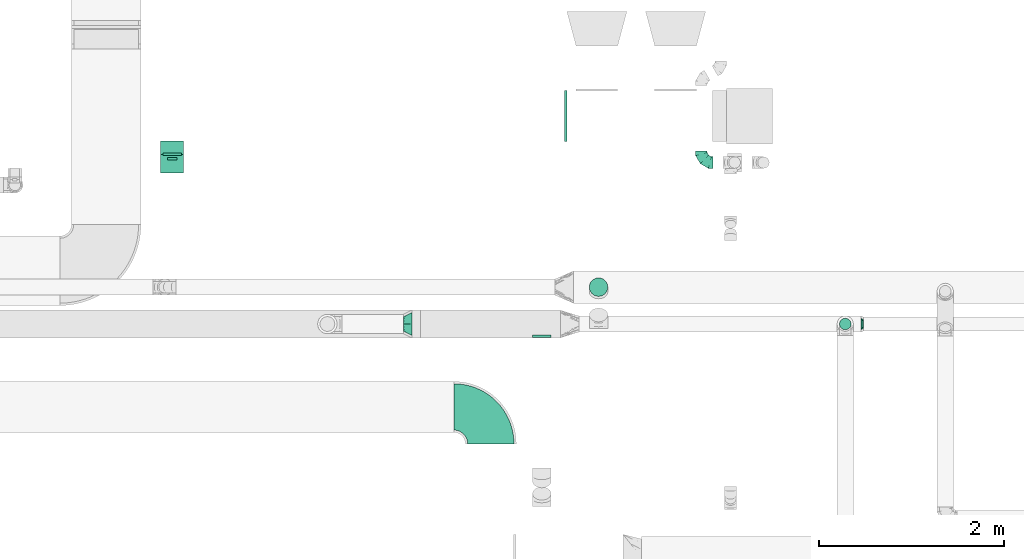
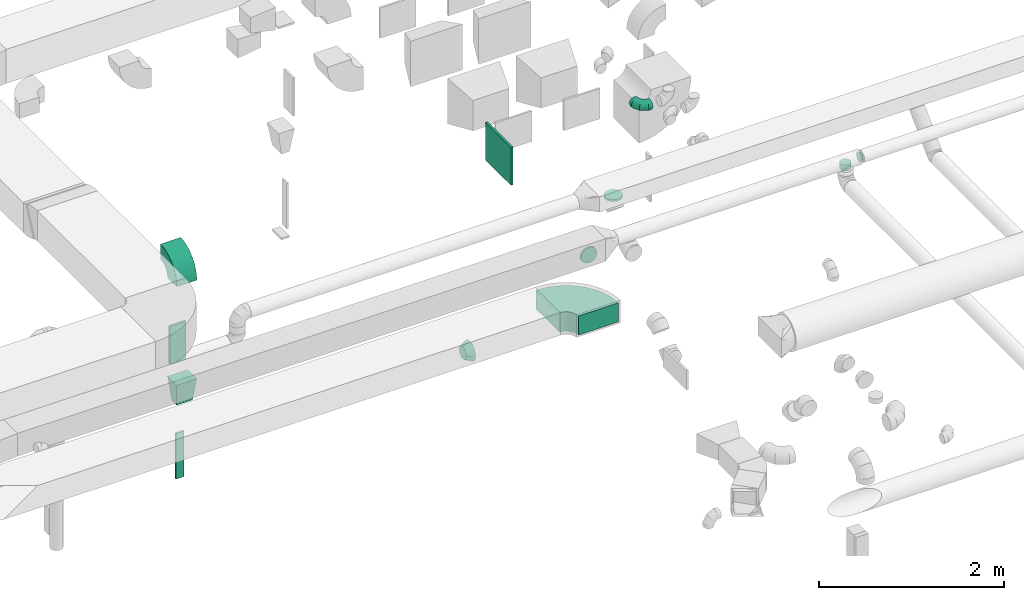
# One storey, part 56 of 97: 12 flow fittings.
"""IFC2X3 building model written with IfcOpenShell, lengths in millimetres."""

from ifc_helpers import new_model, entity, si_unit, converted_unit, derived_unit, direction, frame, frame_2d, origin, origin_2d_with_axis, place, context, subcontext, project, spatial, polyline, circle_curve, parameter, trimmed, segment, composite_curve, rectangle, outline, extrude, faceted_brep, source, transform, mapped, material, type_object, type_shapes, element, save


model = new_model("IFC2X3")

# Units and contexts
model_context = context("Model", 3, precision=0.01, world=origin(), true_north=direction((6.12303176911189e-17, 1.0)))
body_context = subcontext(model_context, "Body", "Model", "MODEL_VIEW")
ifc_project = project(units=[si_unit("LENGTHUNIT", "METRE", prefix="MILLI"), si_unit("AREAUNIT", "SQUARE_METRE"), si_unit("VOLUMEUNIT", "CUBIC_METRE"), converted_unit("PLANEANGLEUNIT", "DEGREE", entity("IfcRatioMeasure", 0.0174532925199433), si_unit("PLANEANGLEUNIT", "RADIAN"), dimensions=[0, 0, 0, 0, 0, 0, 0]), si_unit("MASSUNIT", "GRAM", prefix="KILO"), derived_unit("MASSDENSITYUNIT", [(si_unit("MASSUNIT", "GRAM", prefix="KILO"), 1), (si_unit("LENGTHUNIT", "METRE"), -3)]), derived_unit("MOMENTOFINERTIAUNIT", [(si_unit("LENGTHUNIT", "METRE"), 4)]), si_unit("TIMEUNIT", "SECOND"), si_unit("FREQUENCYUNIT", "HERTZ"), si_unit("THERMODYNAMICTEMPERATUREUNIT", "DEGREE_CELSIUS"), derived_unit("THERMALTRANSMITTANCEUNIT", [(si_unit("MASSUNIT", "GRAM", prefix="KILO"), 1), (si_unit("THERMODYNAMICTEMPERATUREUNIT", "KELVIN"), -1), (si_unit("TIMEUNIT", "SECOND"), -3)]), derived_unit("VOLUMETRICFLOWRATEUNIT", [(si_unit("LENGTHUNIT", "METRE"), 3), (si_unit("TIMEUNIT", "SECOND"), -1)]), derived_unit("MASSFLOWRATEUNIT", [(si_unit("MASSUNIT", "GRAM", prefix="KILO"), 1), (si_unit("TIMEUNIT", "SECOND"), -1)]), derived_unit("ROTATIONALFREQUENCYUNIT", [(si_unit("TIMEUNIT", "SECOND"), -1)]), si_unit("ELECTRICCURRENTUNIT", "AMPERE"), si_unit("ELECTRICVOLTAGEUNIT", "VOLT"), si_unit("POWERUNIT", "WATT"), si_unit("FORCEUNIT", "NEWTON", prefix="KILO"), si_unit("ILLUMINANCEUNIT", "LUX"), si_unit("LUMINOUSFLUXUNIT", "LUMEN"), si_unit("LUMINOUSINTENSITYUNIT", "CANDELA"), derived_unit("USERDEFINED", [(si_unit("MASSUNIT", "GRAM", prefix="KILO"), -1), (si_unit("LENGTHUNIT", "METRE"), -2), (si_unit("TIMEUNIT", "SECOND"), 3), (si_unit("LUMINOUSFLUXUNIT", "LUMEN"), 1)]), derived_unit("LINEARVELOCITYUNIT", [(si_unit("LENGTHUNIT", "METRE"), 1), (si_unit("TIMEUNIT", "SECOND"), -1)]), si_unit("PRESSUREUNIT", "PASCAL"), derived_unit("USERDEFINED", [(si_unit("LENGTHUNIT", "METRE"), -2), (si_unit("MASSUNIT", "GRAM", prefix="KILO"), 1), (si_unit("TIMEUNIT", "SECOND"), -2)]), derived_unit("LINEARFORCEUNIT", [(si_unit("MASSUNIT", "GRAM", prefix="KILO"), 1), (si_unit("LENGTHUNIT", "METRE"), 1), (si_unit("TIMEUNIT", "SECOND"), -2), (si_unit("LENGTHUNIT", "METRE"), -1)]), derived_unit("PLANARFORCEUNIT", [(si_unit("MASSUNIT", "GRAM", prefix="KILO"), 1), (si_unit("LENGTHUNIT", "METRE"), 1), (si_unit("TIMEUNIT", "SECOND"), -2), (si_unit("LENGTHUNIT", "METRE"), -2)])], contexts=[model_context])

# Site, building, storey
site_placement = place(None, origin())
site = spatial("IfcSite", under=ifc_project, at=site_placement, CompositionType="ELEMENT")
building_placement = place(site_placement, origin())
building = spatial("IfcBuilding", under=site, at=building_placement, CompositionType="ELEMENT")
storey_placement = place(building_placement, frame((0.0, 0.0, -4900.0)))
storey = spatial("IfcBuildingStorey", under=building, at=storey_placement, CompositionType="ELEMENT", Elevation=-4900.0)

# Flow fittings
ifc_material = material()
duct_fitting_type_1 = type_object("IfcDuctFittingType", PredefinedType="NOTDEFINED", material=ifc_material)
shared_shape_1 = source(origin(), body_context, "Body", "SweptSolid", [
    extrude(rectangle(XDim=26.0960000000008, YDim=500.0, at=origin_2d_with_axis()), frame((6.95, 0.0, -100.0)), (0.0, 0.0, 1.0), 200.0),
])
type_shapes(duct_fitting_type_1, [shared_shape_1])
flow_fitting_1_placement = place(storey_placement, frame((39021.44, 11073.03, 3050.0), z_axis=(1.0, 0.0, 0.0), x_axis=(0.0, 1.0, 0.0)))
element("IfcFlowFitting", 1, at=flow_fitting_1_placement, inside=storey, type_object=duct_fitting_type_1, material=ifc_material, context=body_context, shape_type="MappedRepresentation", body=[
    mapped(shared_shape_1, transform((0.0, 0.0, 0.0), scale=1.0)),
])
duct_fitting_type_2 = type_object("IfcDuctFittingType", PredefinedType="NOTDEFINED", material=ifc_material)
shared_shape_2 = source(origin(), body_context, "Body", "SweptSolid", [
    extrude(rectangle(XDim=26.0960000000009, YDim=600.0, at=origin_2d_with_axis()), frame((6.95, 0.0, -50.0)), (0.0, 0.0, 1.0), 100.0),
])
type_shapes(duct_fitting_type_2, [shared_shape_2])
flow_fitting_2_placement = place(storey_placement, frame((39021.44, 11023.03, 1600.0), z_axis=(1.0, 0.0, 0.0), x_axis=(0.0, 1.0, 0.0)))
element("IfcFlowFitting", 2, at=flow_fitting_2_placement, inside=storey, type_object=duct_fitting_type_2, material=ifc_material, context=body_context, shape_type="MappedRepresentation", body=[
    mapped(shared_shape_2, transform((0.0, 0.0, 0.0), scale=1.0)),
])
duct_fitting_type_3 = type_object("IfcDuctFittingType", PredefinedType="NOTDEFINED", material=ifc_material)
shared_shape_3 = source(origin(), body_context, "Body", "SweptSolid", [
    extrude(rectangle(XDim=24.9999999999999, YDim=550.0, at=origin_2d_with_axis()), frame((12.5, 0.0, -250.0)), (0.0, 0.0, 1.0), 500.0),
])
type_shapes(duct_fitting_type_3, [shared_shape_3])
flow_fitting_3_placement = place(storey_placement, frame((43284.29, 11489.6, 3800.0), z_axis=(0.0, 0.0, 1.0), x_axis=(-1.0, 0.0, 0.0)))
element("IfcFlowFitting", 3, at=flow_fitting_3_placement, inside=storey, type_object=duct_fitting_type_3, material=ifc_material, context=body_context, shape_type="MappedRepresentation", body=[
    mapped(shared_shape_3, transform((0.0, 0.0, 0.0), scale=1.0)),
])
duct_fitting_type_4 = type_object("IfcDuctFittingType", PredefinedType="NOTDEFINED", material=ifc_material)
shared_shape_4 = source(origin(), body_context, "Body", "Brep", [
    faceted_brep([(-125.0, 0.0, -62.5), (-125.0, -16.18, -60.37), (-125.0, -31.25, -54.13), (-125.0, -44.19, -44.19), (-125.0, -54.13, -31.25), (-125.0, -60.37, -16.18), (-125.0, -62.5, 0.0), (-125.0, -60.37, 16.18), (-125.0, -54.13, 31.25), (-125.0, -44.19, 44.19), (-125.0, -31.25, 54.13), (-125.0, -16.18, 60.37), (-125.0, 0.0, 62.5), (-125.0, 16.18, 60.37), (-125.0, 31.25, 54.13), (-125.0, 44.19, 44.19), (-125.0, 54.13, 31.25), (-125.0, 60.37, 16.18), (-125.0, 62.5, 0.0), (-125.0, 60.37, -16.18), (-125.0, 54.13, -31.25), (-125.0, 44.19, -44.19), (-125.0, 31.25, -54.13), (-125.0, 16.18, -60.37), (-95.84, 16.18, 60.37), (-99.88, 31.25, 54.13), (-91.51, 0.0, 62.5), (-103.35, 44.19, 44.19), (-107.68, 60.37, 16.18), (-108.25, 62.5, 0.0), (-106.01, 54.13, 31.25), (-106.01, 54.13, -31.25), (-103.35, 44.19, -44.19), (-107.68, 60.37, -16.18), (-95.84, 16.18, -60.37), (-91.51, 0.0, -62.5), (-99.88, 31.25, -54.13), (-87.17, -16.18, -60.37), (-83.13, -31.25, -54.13), (-79.66, -44.19, -44.19), (-77.0, -54.13, -31.25), (-75.33, -60.37, -16.18), (-74.76, -62.5, 0.0), (-75.33, -60.37, 16.18), (-77.0, -54.13, 31.25), (-79.66, -44.19, 44.19), (-83.13, -31.25, 54.13), (-87.17, -16.18, 60.37), (-45.34, 45.34, 60.37), (-56.37, 56.37, 54.13), (-33.49, 33.49, 62.5), (-65.85, 65.85, 44.19), (-73.12, 73.12, 31.25), (-77.69, 77.69, 16.18), (-79.25, 79.25, 0.0), (-77.69, 77.69, -16.18), (-73.12, 73.12, -31.25), (-65.85, 65.85, -44.19), (-45.34, 45.34, -60.37), (-33.49, 33.49, -62.5), (-56.37, 56.37, -54.13), (-21.65, 21.65, -60.37), (-10.62, 10.62, -54.13), (-1.14, 1.14, -44.19), (6.13, -6.13, -31.25), (10.7, -10.7, -16.18), (12.26, -12.26, 0.0), (10.7, -10.7, 16.18), (6.13, -6.13, 31.25), (-1.14, 1.14, 44.19), (-10.62, 10.62, 54.13), (-21.65, 21.65, 60.37), (-16.18, 95.84, 60.37), (-31.25, 99.88, 54.13), (0.0, 91.51, 62.5), (-44.19, 103.35, 44.19), (-54.13, 106.01, 31.25), (-60.37, 107.68, 16.18), (-62.5, 108.25, 0.0), (-60.37, 107.68, -16.18), (-54.13, 106.01, -31.25), (-44.19, 103.35, -44.19), (-16.18, 95.84, -60.37), (0.0, 91.51, -62.5), (-31.25, 99.88, -54.13), (16.18, 87.17, -60.37), (31.25, 83.13, -54.13), (44.19, 79.66, -44.19), (54.13, 77.0, -31.25), (60.37, 75.33, -16.18), (62.5, 74.76, 0.0), (60.37, 75.33, 16.18), (54.13, 77.0, 31.25), (44.19, 79.66, 44.19), (31.25, 83.13, 54.13), (16.18, 87.17, 60.37), (-16.18, 125.0, -60.37), (-31.25, 125.0, -54.13), (-44.19, 125.0, -44.19), (-54.13, 125.0, -31.25), (-60.37, 125.0, -16.18), (-62.5, 125.0, 0.0), (-60.37, 125.0, 16.18), (-54.13, 125.0, 31.25), (-44.19, 125.0, 44.19), (-31.25, 125.0, 54.13), (-16.18, 125.0, 60.37), (0.0, 125.0, 62.5), (16.18, 125.0, 60.37), (31.25, 125.0, 54.13), (44.19, 125.0, 44.19), (54.13, 125.0, 31.25), (60.37, 125.0, 16.18), (62.5, 125.0, 0.0), (60.37, 125.0, -16.18), (54.13, 125.0, -31.25), (44.19, 125.0, -44.19), (31.25, 125.0, -54.13), (16.18, 125.0, -60.37), (0.0, 125.0, -62.5)], [[[0, 1, 2, 3, 4, 5, 6, 7, 8, 9, 10, 11, 12, 13, 14, 15, 16, 17, 18, 19, 20, 21, 22, 23]], [[24, 25, 14, 13]], [[26, 24, 13, 12]], [[14, 25, 27, 15]], [[28, 29, 18, 17]], [[30, 28, 17, 16]], [[15, 27, 30, 16]], [[20, 31, 32, 21]], [[33, 31, 20, 19]], [[18, 29, 33, 19]], [[34, 35, 0, 23]], [[36, 34, 23, 22]], [[21, 32, 36, 22]], [[1, 0, 35, 37]], [[2, 1, 37, 38]], [[38, 39, 3, 2]], [[5, 4, 40, 41]], [[6, 5, 41, 42]], [[39, 40, 4, 3]], [[6, 42, 43, 7]], [[7, 43, 44, 8]], [[45, 9, 8, 44]], [[9, 45, 46, 10]], [[10, 46, 47, 11]], [[26, 12, 11, 47]], [[48, 49, 25, 24]], [[50, 48, 24, 26]], [[27, 25, 49, 51]], [[52, 53, 28, 30]], [[51, 52, 30, 27]], [[29, 28, 53, 54]], [[55, 56, 31, 33]], [[54, 55, 33, 29]], [[57, 32, 31, 56]], [[58, 59, 35, 34]], [[60, 58, 34, 36]], [[57, 60, 36, 32]], [[37, 35, 59, 61]], [[38, 37, 61, 62]], [[39, 38, 62, 63]], [[41, 40, 64, 65]], [[42, 41, 65, 66]], [[63, 64, 40, 39]], [[43, 42, 66, 67]], [[44, 43, 67, 68]], [[68, 69, 45, 44]], [[46, 45, 69, 70]], [[47, 46, 70, 71]], [[26, 47, 71, 50]], [[72, 73, 49, 48]], [[74, 72, 48, 50]], [[51, 49, 73, 75]], [[76, 77, 53, 52]], [[75, 76, 52, 51]], [[54, 53, 77, 78]], [[79, 80, 56, 55]], [[78, 79, 55, 54]], [[81, 57, 56, 80]], [[82, 83, 59, 58]], [[84, 82, 58, 60]], [[81, 84, 60, 57]], [[61, 59, 83, 85]], [[62, 61, 85, 86]], [[63, 62, 86, 87]], [[65, 64, 88, 89]], [[66, 65, 89, 90]], [[87, 88, 64, 63]], [[67, 66, 90, 91]], [[68, 67, 91, 92]], [[92, 93, 69, 68]], [[70, 69, 93, 94]], [[71, 70, 94, 95]], [[50, 71, 95, 74]], [[96, 97, 98, 99, 100, 101, 102, 103, 104, 105, 106, 107, 108, 109, 110, 111, 112, 113, 114, 115, 116, 117, 118, 119]], [[72, 74, 107, 106]], [[73, 72, 106, 105]], [[75, 73, 105, 104]], [[77, 76, 103, 102]], [[78, 77, 102, 101]], [[75, 104, 103, 76]], [[78, 101, 100, 79]], [[79, 100, 99, 80]], [[80, 99, 98, 81]], [[96, 119, 83, 82]], [[97, 96, 82, 84]], [[84, 81, 98, 97]], [[83, 119, 118, 85]], [[85, 118, 117, 86]], [[116, 87, 86, 117]], [[88, 115, 114, 89]], [[89, 114, 113, 90]], [[115, 88, 87, 116]], [[91, 90, 113, 112]], [[92, 91, 112, 111]], [[111, 110, 93, 92]], [[95, 94, 109, 108]], [[74, 95, 108, 107]], [[110, 109, 94, 93]]]),
])
type_shapes(duct_fitting_type_4, [shared_shape_4])
flow_fitting_4_placement = place(storey_placement, frame((44736.23, 10988.58, 4200.0), z_axis=(0.0, 0.0, 1.0), x_axis=(0.0, -1.0, 0.0)))
element("IfcFlowFitting", 4, at=flow_fitting_4_placement, inside=storey, type_object=duct_fitting_type_4, material=ifc_material, context=body_context, shape_type="MappedRepresentation", body=[
    mapped(shared_shape_4, transform((0.0, 0.0, 0.0), scale=1.0)),
])
duct_fitting_type_5 = type_object("IfcDuctFittingType", PredefinedType="NOTDEFINED", material=ifc_material)
shared_shape_5 = source(origin(), body_context, "Body", "Brep", [
    faceted_brep([(20.0, 25.88, -96.59), (20.0, 50.0, -86.6), (20.0, 70.71, -70.71), (20.0, 86.6, -50.0), (20.0, 96.59, -25.88), (20.0, 100.0, 0.0), (20.0, 96.59, 25.88), (20.0, 86.6, 50.0), (20.0, 70.71, 70.71), (20.0, 50.0, 86.6), (20.0, 25.88, 96.59), (20.0, 0.0, 100.0), (20.0, -25.88, 96.59), (20.0, -50.0, 86.6), (20.0, -70.71, 70.71), (20.0, -86.6, 50.0), (20.0, -96.59, 25.88), (20.0, -100.0, 0.0), (20.0, -96.59, -25.88), (20.0, -86.6, -50.0), (20.0, -70.71, -70.71), (20.0, -50.0, -86.6), (20.0, -25.88, -96.59), (20.0, 0.0, -100.0), (0.0, 0.0, 100.0), (0.0, 25.88, 96.59), (-6.1, 25.88, 96.59), (-6.1, 0.0, 100.0), (0.0, 50.0, 86.6), (-6.1, 50.0, 86.6), (0.0, 70.71, 70.71), (-6.1, 70.71, 70.71), (0.0, 86.6, 50.0), (0.0, 96.59, 25.88), (-6.1, 96.59, 25.88), (-6.1, 86.6, 50.0), (0.0, 100.0, 0.0), (-6.1, 100.0, 0.0), (0.0, 96.59, -25.88), (-6.1, 96.59, -25.88), (0.0, 86.6, -50.0), (-6.1, 86.6, -50.0), (0.0, 70.71, -70.71), (-6.1, 70.71, -70.71), (0.0, 50.0, -86.6), (0.0, 25.88, -96.59), (-6.1, 25.88, -96.59), (-6.1, 50.0, -86.6), (0.0, 0.0, -100.0), (-6.1, 0.0, -100.0), (0.0, -25.88, -96.59), (-6.1, -25.88, -96.59), (0.0, -50.0, -86.6), (-6.1, -50.0, -86.6), (0.0, -70.71, -70.71), (-6.1, -70.71, -70.71), (0.0, -86.6, -50.0), (0.0, -96.59, -25.88), (-6.1, -96.59, -25.88), (-6.1, -86.6, -50.0), (0.0, -100.0, 0.0), (-6.1, -100.0, 0.0), (0.0, -96.59, 25.88), (-6.1, -96.59, 25.88), (0.0, -86.6, 50.0), (-6.1, -86.6, 50.0), (0.0, -70.71, 70.71), (-6.1, -70.71, 70.71), (0.0, -50.0, 86.6), (0.0, -25.88, 96.59), (-6.1, -25.88, 96.59), (-6.1, -50.0, 86.6)], [[[0, 1, 2, 3, 4, 5, 6, 7, 8, 9, 10, 11, 12, 13, 14, 15, 16, 17, 18, 19, 20, 21, 22, 23]], [[24, 11, 10, 25, 26, 27]], [[25, 10, 9, 28, 29, 26]], [[28, 9, 8, 30, 31, 29]], [[32, 7, 6, 33, 34, 35]], [[33, 6, 5, 36, 37, 34]], [[30, 8, 7, 32, 35, 31]], [[36, 5, 4, 38, 39, 37]], [[38, 4, 3, 40, 41, 39]], [[40, 3, 2, 42, 43, 41]], [[44, 1, 0, 45, 46, 47]], [[45, 0, 23, 48, 49, 46]], [[42, 2, 1, 44, 47, 43]], [[48, 23, 22, 50, 51, 49]], [[50, 22, 21, 52, 53, 51]], [[52, 21, 20, 54, 55, 53]], [[56, 19, 18, 57, 58, 59]], [[57, 18, 17, 60, 61, 58]], [[54, 20, 19, 56, 59, 55]], [[60, 17, 16, 62, 63, 61]], [[62, 16, 15, 64, 65, 63]], [[64, 15, 14, 66, 67, 65]], [[68, 13, 12, 69, 70, 71]], [[69, 12, 11, 24, 27, 70]], [[66, 14, 13, 68, 71, 67]], [[49, 51, 53, 55, 59, 58, 61, 63, 65, 67, 71, 70, 27, 26, 29, 31, 35, 34, 37, 39, 41, 43, 47, 46]]]),
])
type_shapes(duct_fitting_type_5, [shared_shape_5])
flow_fitting_5_placement = place(storey_placement, frame((43012.65, 9120.01, 4000.0), z_axis=(0.0, 0.0, -1.0), x_axis=(0.0, -1.0, 0.0)))
element("IfcFlowFitting", 5, at=flow_fitting_5_placement, inside=storey, type_object=duct_fitting_type_5, material=ifc_material, context=body_context, shape_type="MappedRepresentation", body=[
    mapped(shared_shape_5, transform((0.0, 0.0, 0.0), scale=1.0)),
])
duct_fitting_type_6 = type_object("IfcDuctFittingType", PredefinedType="NOTDEFINED", material=ifc_material)
shared_shape_6 = source(origin(), body_context, "Body", "Brep", [
    faceted_brep([(300.0, -100.0, 125.0), (300.0, -100.0, -125.0), (300.0, 100.0, -125.0), (300.0, 100.0, 125.0), (0.0, -50.0, 100.0), (0.0, 50.0, 100.0), (0.0, 50.0, -100.0), (0.0, -50.0, -100.0)], [[[0, 1, 2, 3]], [[4, 5, 6, 7]], [[4, 7, 1, 0]], [[7, 6, 2, 1]], [[6, 5, 3, 2]], [[5, 4, 0, 3]]]),
])
type_shapes(duct_fitting_type_6, [shared_shape_6])
flow_fitting_6_placement = place(storey_placement, frame((39021.44, 10973.03, 2350.0), z_axis=(1.0, 0.0, 0.0), x_axis=(0.0, 0.0, 1.0)))
element("IfcFlowFitting", 6, at=flow_fitting_6_placement, inside=storey, type_object=duct_fitting_type_6, material=ifc_material, context=body_context, shape_type="MappedRepresentation", body=[
    mapped(shared_shape_6, transform((0.0, 0.0, 0.0), scale=1.0)),
])
duct_fitting_type_7 = type_object("IfcDuctFittingType", PredefinedType="NOTDEFINED", material=ifc_material)
shared_shape_7 = source(origin(), body_context, "Body", "Brep", [
    faceted_brep([(90.0, -73.91, 30.61), (90.0, -76.96, 15.31), (90.0, -80.0, 0.0), (90.0, -76.96, -15.31), (90.0, -73.91, -30.61), (90.0, -65.24, -43.59), (90.0, -56.57, -56.57), (90.0, -43.59, -65.24), (90.0, -30.61, -73.91), (90.0, -15.31, -76.96), (90.0, 0.0, -80.0), (90.0, 15.31, -76.96), (90.0, 30.61, -73.91), (90.0, 43.59, -65.24), (90.0, 56.57, -56.57), (90.0, 65.24, -43.59), (90.0, 73.91, -30.61), (90.0, 76.96, -15.31), (90.0, 80.0, 0.0), (90.0, 76.96, 15.31), (90.0, 73.91, 30.61), (90.0, 65.24, 43.59), (90.0, 56.57, 56.57), (90.0, 43.59, 65.24), (90.0, 30.61, 73.91), (90.0, 15.31, 76.96), (90.0, 0.0, 80.0), (90.0, -15.31, 76.96), (90.0, -30.61, 73.91), (90.0, -43.59, 65.24), (90.0, -56.57, 56.57), (90.0, -65.24, 43.59), (0.0, -125.0, 0.0), (0.0, -118.88, 38.63), (0.0, -101.13, 73.47), (0.0, -73.47, 101.13), (0.0, -38.63, 118.88), (0.0, 0.0, 125.0), (0.0, 38.63, 118.88), (0.0, 73.47, 101.13), (0.0, 101.13, 73.47), (0.0, 118.88, 38.63), (0.0, 125.0, 0.0), (0.0, 118.88, -38.63), (0.0, 101.13, -73.47), (0.0, 73.47, -101.13), (0.0, 38.63, -118.88), (0.0, 0.0, -125.0), (0.0, -38.63, -118.88), (0.0, -73.47, -101.13), (0.0, -101.13, -73.47), (0.0, -118.88, -38.63)], [[[0, 1, 2, 3, 4, 5, 6, 7, 8, 9, 10, 11, 12, 13, 14, 15, 16, 17, 18, 19, 20, 21, 22, 23, 24, 25, 26, 27, 28, 29, 30, 31]], [[32, 33, 34, 35, 36, 37, 38, 39, 40, 41, 42, 43, 44, 45, 46, 47, 48, 49, 50, 51]], [[37, 25, 38]], [[24, 39, 38]], [[40, 22, 21, 20]], [[23, 22, 39, 24]], [[41, 20, 19]], [[18, 42, 19]], [[25, 24, 38]], [[40, 20, 41]], [[19, 42, 41]], [[25, 37, 26]], [[22, 40, 39]], [[32, 1, 33]], [[0, 34, 33]], [[35, 30, 29, 28]], [[31, 30, 34, 0]], [[36, 28, 27]], [[26, 37, 27]], [[1, 0, 33]], [[35, 28, 36]], [[27, 37, 36]], [[1, 32, 2]], [[30, 35, 34]], [[47, 9, 48]], [[8, 49, 48]], [[50, 6, 5, 4]], [[7, 6, 49, 8]], [[51, 4, 3]], [[2, 32, 3]], [[9, 8, 48]], [[50, 4, 51]], [[3, 32, 51]], [[9, 47, 10]], [[6, 50, 49]], [[42, 17, 43]], [[16, 44, 43]], [[45, 14, 13, 12]], [[15, 14, 44, 16]], [[46, 12, 11]], [[10, 47, 11]], [[17, 16, 43]], [[45, 12, 46]], [[11, 47, 46]], [[17, 42, 18]], [[14, 45, 44]]]),
])
type_shapes(duct_fitting_type_7, [shared_shape_7])
flow_fitting_7_placement = place(storey_placement, frame((41611.37, 9245.01, 3147.0), z_axis=(0.0, 0.0, 1.0), x_axis=(-1.0, 0.0, 0.0)))
element("IfcFlowFitting", 7, at=flow_fitting_7_placement, inside=storey, type_object=duct_fitting_type_7, material=ifc_material, context=body_context, shape_type="MappedRepresentation", body=[
    mapped(shared_shape_7, transform((0.0, 0.0, 0.0), scale=1.0)),
])
duct_fitting_type_8 = type_object("IfcDuctFittingType", PredefinedType="NOTDEFINED", material=ifc_material)
shared_shape_8 = source(origin(), body_context, "Body", "Brep", [
    faceted_brep([(25.0, 0.0, -62.5), (25.0, 12.45, -60.02), (25.0, 23.92, -57.74), (25.0, 34.06, -50.97), (25.0, 44.19, -44.19), (25.0, 50.97, -34.06), (25.0, 57.74, -23.92), (25.0, 60.02, -12.45), (25.0, 62.5, 0.0), (25.0, 60.02, 12.45), (25.0, 57.74, 23.92), (25.0, 50.97, 34.06), (25.0, 44.19, 44.19), (25.0, 34.06, 50.97), (25.0, 23.92, 57.74), (25.0, 12.45, 60.02), (25.0, 0.0, 62.5), (25.0, -12.45, 60.02), (25.0, -23.92, 57.74), (25.0, -34.06, 50.97), (25.0, -44.19, 44.19), (25.0, -50.97, 34.06), (25.0, -57.74, 23.92), (25.0, -60.02, 12.45), (25.0, -62.5, 0.0), (25.0, -60.02, -12.45), (25.0, -57.74, -23.92), (25.0, -50.97, -34.06), (25.0, -44.19, -44.19), (25.0, -34.06, -50.97), (25.0, -23.92, -57.74), (25.0, -12.45, -60.02), (0.0, -19.13, -46.19), (0.0, -27.24, -40.77), (0.0, -35.36, -35.36), (0.0, -40.77, -27.24), (0.0, -46.19, -19.13), (0.0, -48.1, -9.57), (0.0, -50.0, 0.0), (0.0, -48.1, 9.57), (0.0, -46.19, 19.13), (0.0, -40.77, 27.24), (0.0, -35.36, 35.36), (0.0, -27.24, 40.77), (0.0, -19.13, 46.19), (0.0, -9.57, 48.1), (0.0, 0.0, 50.0), (0.0, 9.57, 48.1), (0.0, 19.13, 46.19), (0.0, 27.24, 40.77), (0.0, 35.36, 35.36), (0.0, 40.77, 27.24), (0.0, 46.19, 19.13), (0.0, 48.1, 9.57), (0.0, 50.0, 0.0), (0.0, 48.1, -9.57), (0.0, 46.19, -19.13), (0.0, 40.77, -27.24), (0.0, 35.36, -35.36), (0.0, 27.24, -40.77), (0.0, 19.13, -46.19), (0.0, 9.57, -48.1), (0.0, 0.0, -50.0), (0.0, -9.57, -48.1)], [[[0, 1, 2, 3, 4, 5, 6, 7, 8, 9, 10, 11, 12, 13, 14, 15, 16, 17, 18, 19, 20, 21, 22, 23, 24, 25, 26, 27, 28, 29, 30, 31]], [[32, 33, 34, 35, 36, 37, 38, 39, 40, 41, 42, 43, 44, 45, 46, 47, 48, 49, 50, 51, 52, 53, 54, 55, 56, 57, 58, 59, 60, 61, 62, 63]], [[52, 10, 9, 8, 54, 53]], [[51, 50, 12, 11, 10, 52]], [[47, 46, 16, 15, 14, 48]], [[49, 48, 14, 13, 12, 50]], [[44, 18, 17, 16, 46, 45]], [[43, 42, 20, 19, 18, 44]], [[39, 38, 24, 23, 22, 40]], [[41, 40, 22, 21, 20, 42]], [[36, 26, 25, 24, 38, 37]], [[35, 34, 28, 27, 26, 36]], [[63, 62, 0, 31, 30, 32]], [[33, 32, 30, 29, 28, 34]], [[60, 2, 1, 0, 62, 61]], [[59, 58, 4, 3, 2, 60]], [[55, 54, 8, 7, 6, 56]], [[57, 56, 6, 5, 4, 58]]]),
])
type_shapes(duct_fitting_type_8, [shared_shape_8])
flow_fitting_8_placement = place(storey_placement, frame((46485.51, 9245.01, 4000.0), z_axis=(0.0, 0.0, 1.0), x_axis=(-1.0, 0.0, 0.0)))
element("IfcFlowFitting", 8, at=flow_fitting_8_placement, inside=storey, type_object=duct_fitting_type_8, material=ifc_material, context=body_context, shape_type="MappedRepresentation", body=[
    mapped(shared_shape_8, transform((0.0, 0.0, 0.0), scale=1.0)),
])
duct_fitting_type_9 = type_object("IfcDuctFittingType", PredefinedType="NOTDEFINED", material=ifc_material)
shared_shape_9 = source(origin(), body_context, "Body", "Brep", [
    faceted_brep([(20.0, 0.0, -100.0), (20.0, 25.88, -96.59), (20.0, 50.0, -86.6), (20.0, 70.71, -70.71), (20.0, 86.6, -50.0), (20.0, 96.59, -25.88), (20.0, 100.0, 0.0), (20.0, 96.59, 25.88), (20.0, 86.6, 50.0), (20.0, 70.71, 70.71), (20.0, 50.0, 86.6), (20.0, 25.88, 96.59), (20.0, 0.0, 100.0), (20.0, -25.88, 96.59), (20.0, -50.0, 86.6), (20.0, -70.71, 70.71), (20.0, -86.6, 50.0), (20.0, -96.59, 25.88), (20.0, -100.0, 0.0), (20.0, -96.59, -25.88), (20.0, -86.6, -50.0), (20.0, -70.71, -70.71), (20.0, -50.0, -86.6), (20.0, -25.88, -96.59), (0.0, 0.0, 100.0), (-6.1, 0.0, 100.0), (-6.1, -25.88, 96.59), (0.0, -25.88, 96.59), (-6.1, -50.0, 86.6), (0.0, -50.0, 86.6), (0.0, -70.71, 70.71), (-6.1, -70.71, 70.71), (0.0, -86.6, 50.0), (-6.1, -86.6, 50.0), (-6.1, -96.59, 25.88), (0.0, -96.59, 25.88), (-6.1, -100.0, 0.0), (0.0, -100.0, 0.0), (-6.1, -96.59, -25.88), (0.0, -96.59, -25.88), (-6.1, -86.6, -50.0), (0.0, -86.6, -50.0), (0.0, -70.71, -70.71), (-6.1, -70.71, -70.71), (0.0, -50.0, -86.6), (-6.1, -50.0, -86.6), (-6.1, -25.88, -96.59), (0.0, -25.88, -96.59), (-6.1, 0.0, -100.0), (0.0, 0.0, -100.0), (-6.1, 25.88, -96.59), (0.0, 25.88, -96.59), (-6.1, 50.0, -86.6), (0.0, 50.0, -86.6), (0.0, 70.71, -70.71), (-6.1, 70.71, -70.71), (0.0, 86.6, -50.0), (-6.1, 86.6, -50.0), (-6.1, 96.59, -25.88), (0.0, 96.59, -25.88), (-6.1, 100.0, 0.0), (0.0, 100.0, 0.0), (-6.1, 96.59, 25.88), (0.0, 96.59, 25.88), (-6.1, 86.6, 50.0), (0.0, 86.6, 50.0), (0.0, 70.71, 70.71), (-6.1, 70.71, 70.71), (0.0, 50.0, 86.6), (-6.1, 50.0, 86.6), (-6.1, 25.88, 96.59), (0.0, 25.88, 96.59)], [[[0, 1, 2, 3, 4, 5, 6, 7, 8, 9, 10, 11, 12, 13, 14, 15, 16, 17, 18, 19, 20, 21, 22, 23]], [[13, 12, 24, 25, 26, 27]], [[14, 13, 27, 26, 28, 29]], [[30, 15, 14, 29, 28, 31]], [[17, 16, 32, 33, 34, 35]], [[18, 17, 35, 34, 36, 37]], [[32, 16, 15, 30, 31, 33]], [[19, 18, 37, 36, 38, 39]], [[20, 19, 39, 38, 40, 41]], [[42, 21, 20, 41, 40, 43]], [[23, 22, 44, 45, 46, 47]], [[0, 23, 47, 46, 48, 49]], [[44, 22, 21, 42, 43, 45]], [[1, 0, 49, 48, 50, 51]], [[2, 1, 51, 50, 52, 53]], [[54, 3, 2, 53, 52, 55]], [[5, 4, 56, 57, 58, 59]], [[6, 5, 59, 58, 60, 61]], [[56, 4, 3, 54, 55, 57]], [[7, 6, 61, 60, 62, 63]], [[8, 7, 63, 62, 64, 65]], [[66, 9, 8, 65, 64, 67]], [[11, 10, 68, 69, 70, 71]], [[12, 11, 71, 70, 25, 24]], [[68, 10, 9, 66, 67, 69]], [[46, 45, 43, 40, 38, 36, 34, 33, 31, 28, 26, 25, 70, 69, 67, 64, 62, 60, 58, 57, 55, 52, 50, 48]]]),
])
type_shapes(duct_fitting_type_9, [shared_shape_9])
flow_fitting_9_placement = place(storey_placement, frame((43625.66, 9643.15, 4250.0), z_axis=(1.0, 0.0, 0.0), x_axis=(0.0, 0.0, -1.0)))
element("IfcFlowFitting", 9, at=flow_fitting_9_placement, inside=storey, type_object=duct_fitting_type_9, material=ifc_material, context=body_context, shape_type="MappedRepresentation", body=[
    mapped(shared_shape_9, transform((0.0, 0.0, 0.0), scale=1.0)),
])
duct_fitting_type_10 = type_object("IfcDuctFittingType", PredefinedType="NOTDEFINED", material=ifc_material)
shared_shape_10 = source(origin(), body_context, "Body", "Brep", [
    faceted_brep([(20.0, 0.0, -62.5), (20.0, 16.18, -60.37), (20.0, 31.25, -54.13), (20.0, 44.19, -44.19), (20.0, 54.13, -31.25), (20.0, 60.37, -16.18), (20.0, 62.5, 0.0), (20.0, 60.37, 16.18), (20.0, 54.13, 31.25), (20.0, 44.19, 44.19), (20.0, 31.25, 54.13), (20.0, 16.18, 60.37), (20.0, 0.0, 62.5), (20.0, -16.18, 60.37), (20.0, -31.25, 54.13), (20.0, -44.19, 44.19), (20.0, -54.13, 31.25), (20.0, -60.37, 16.18), (20.0, -62.5, 0.0), (20.0, -60.37, -16.18), (20.0, -54.13, -31.25), (20.0, -44.19, -44.19), (20.0, -31.25, -54.13), (20.0, -16.18, -60.37), (0.0, 0.0, 62.5), (-56.4, 0.0, 62.5), (-56.4, -16.18, 60.37), (0.0, -16.18, 60.37), (-56.4, -31.25, 54.13), (0.0, -31.25, 54.13), (0.0, -44.19, 44.19), (-56.4, -44.19, 44.19), (0.0, -54.13, 31.25), (-56.4, -54.13, 31.25), (-56.4, -60.37, 16.18), (0.0, -60.37, 16.18), (-56.4, -62.5, 0.0), (0.0, -62.5, 0.0), (-56.4, -60.37, -16.18), (0.0, -60.37, -16.18), (-56.4, -54.13, -31.25), (0.0, -54.13, -31.25), (0.0, -44.19, -44.19), (-56.4, -44.19, -44.19), (0.0, -31.25, -54.13), (-56.4, -31.25, -54.13), (-56.4, -16.18, -60.37), (0.0, -16.18, -60.37), (-56.4, 0.0, -62.5), (0.0, 0.0, -62.5), (-56.4, 16.18, -60.37), (0.0, 16.18, -60.37), (-56.4, 31.25, -54.13), (0.0, 31.25, -54.13), (0.0, 44.19, -44.19), (-56.4, 44.19, -44.19), (0.0, 54.13, -31.25), (-56.4, 54.13, -31.25), (-56.4, 60.37, -16.18), (0.0, 60.37, -16.18), (-56.4, 62.5, 0.0), (0.0, 62.5, 0.0), (-56.4, 60.37, 16.18), (0.0, 60.37, 16.18), (-56.4, 54.13, 31.25), (0.0, 54.13, 31.25), (0.0, 44.19, 44.19), (-56.4, 44.19, 44.19), (0.0, 31.25, 54.13), (-56.4, 31.25, 54.13), (-56.4, 16.18, 60.37), (0.0, 16.18, 60.37)], [[[0, 1, 2, 3, 4, 5, 6, 7, 8, 9, 10, 11, 12, 13, 14, 15, 16, 17, 18, 19, 20, 21, 22, 23]], [[13, 12, 24, 25, 26, 27]], [[14, 13, 27, 26, 28, 29]], [[30, 15, 14, 29, 28, 31]], [[17, 16, 32, 33, 34, 35]], [[18, 17, 35, 34, 36, 37]], [[32, 16, 15, 30, 31, 33]], [[19, 18, 37, 36, 38, 39]], [[20, 19, 39, 38, 40, 41]], [[42, 21, 20, 41, 40, 43]], [[23, 22, 44, 45, 46, 47]], [[0, 23, 47, 46, 48, 49]], [[44, 22, 21, 42, 43, 45]], [[1, 0, 49, 48, 50, 51]], [[2, 1, 51, 50, 52, 53]], [[54, 3, 2, 53, 52, 55]], [[5, 4, 56, 57, 58, 59]], [[6, 5, 59, 58, 60, 61]], [[56, 4, 3, 54, 55, 57]], [[7, 6, 61, 60, 62, 63]], [[8, 7, 63, 62, 64, 65]], [[66, 9, 8, 65, 64, 67]], [[11, 10, 68, 69, 70, 71]], [[12, 11, 71, 70, 25, 24]], [[68, 10, 9, 66, 67, 69]], [[46, 45, 43, 40, 38, 36, 34, 33, 31, 28, 26, 25, 70, 69, 67, 64, 62, 60, 58, 57, 55, 52, 50, 48]]]),
])
type_shapes(duct_fitting_type_10, [shared_shape_10])
flow_fitting_10_placement = place(storey_placement, frame((46289.39, 9245.01, 3937.5), z_axis=(0.0, -1.0, 1.27955974968952e-05), x_axis=(0.0, -1.27955975335671e-05, -1.0)))
element("IfcFlowFitting", 10, at=flow_fitting_10_placement, inside=storey, type_object=duct_fitting_type_10, material=ifc_material, context=body_context, shape_type="MappedRepresentation", body=[
    mapped(shared_shape_10, transform((0.0, 0.0, 0.0), scale=1.0)),
])
duct_fitting_type_11 = type_object("IfcDuctFittingType", PredefinedType="NOTDEFINED", material=ifc_material)
shared_shape_11 = source(origin(), body_context, "Body", "SweptSolid", [
    extrude(outline(composite_curve([segment(polyline([(-450.0, -200.0), (50.0, -200.0)]), True, "CONTINUOUS"), segment(trimmed(circle_curve(frame_2d((200.0, -200.0), x_axis=(0.0, 1.0)), 150.0), [parameter(0.0)], [parameter(90.0000000000001)], True, "PARAMETER"), False, "CONTINUOUS"), segment(polyline([(200.0, -50.0), (200.0, 450.0)]), True, "CONTINUOUS"), segment(trimmed(circle_curve(frame_2d((200.0, -200.0), x_axis=(0.0, 1.0)), 650.0), [parameter(0.0)], [parameter(90.0000000000001)], True, "PARAMETER"), True, "CONTINUOUS")], self_intersect=False)), frame((-200.0, 200.0, -125.0), z_axis=(0.0, 0.0, 1.0), x_axis=(-1.0, 0.0, 0.0)), (0.0, 0.0, 1.0), 250.0),
])
type_shapes(duct_fitting_type_11, [shared_shape_11])
flow_fitting_11_placement = place(storey_placement, frame((42462.6, 8349.88, 4050.0), z_axis=(0.0, 0.0, 1.0), x_axis=(0.0, 1.0, 0.0)))
element("IfcFlowFitting", 11, at=flow_fitting_11_placement, inside=storey, type_object=duct_fitting_type_11, material=ifc_material, context=body_context, shape_type="MappedRepresentation", body=[
    mapped(shared_shape_11, transform((0.0, 0.0, 0.0), scale=1.0)),
])
duct_fitting_type_12 = type_object("IfcDuctFittingType", PredefinedType="NOTDEFINED", material=ifc_material)
shared_shape_12 = source(origin(), body_context, "Body", "SweptSolid", [
    extrude(outline(composite_curve([segment(polyline([(-225.0, -125.0), (-25.0, -125.0)]), True, "CONTINUOUS"), segment(trimmed(circle_curve(frame_2d((125.0, -125.0), x_axis=(0.0, 1.0)), 150.0), [parameter(0.0)], [parameter(90.0)], True, "PARAMETER"), False, "CONTINUOUS"), segment(polyline([(125.0, 25.0), (125.0, 225.0)]), True, "CONTINUOUS"), segment(trimmed(circle_curve(frame_2d((125.0, -125.0), x_axis=(0.0, 1.0)), 350.0), [parameter(0.0)], [parameter(90.0)], True, "PARAMETER"), True, "CONTINUOUS")], self_intersect=False)), frame((-125.0, 125.0, -125.0), z_axis=(0.0, 0.0, 1.0), x_axis=(-1.0, 0.0, 0.0)), (0.0, 0.0, 1.0), 250.0),
])
type_shapes(duct_fitting_type_12, [shared_shape_12])
flow_fitting_12_placement = place(storey_placement, frame((39021.44, 10973.03, 4200.0), z_axis=(1.0, 0.0, 0.0), x_axis=(0.0, -1.0, 0.0)))
element("IfcFlowFitting", 12, at=flow_fitting_12_placement, inside=storey, type_object=duct_fitting_type_12, material=ifc_material, context=body_context, shape_type="MappedRepresentation", body=[
    mapped(shared_shape_12, transform((0.0, 0.0, 0.0), scale=1.0)),
])

save(model, "model.ifc")
